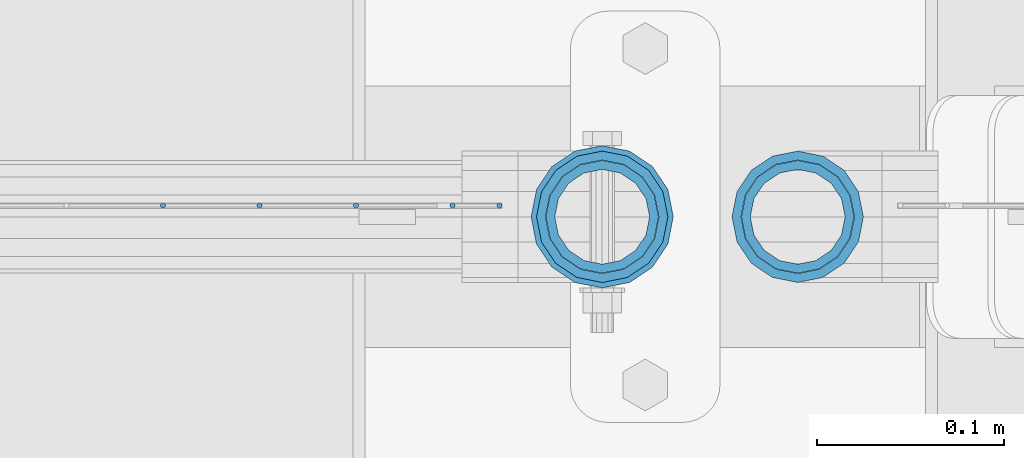
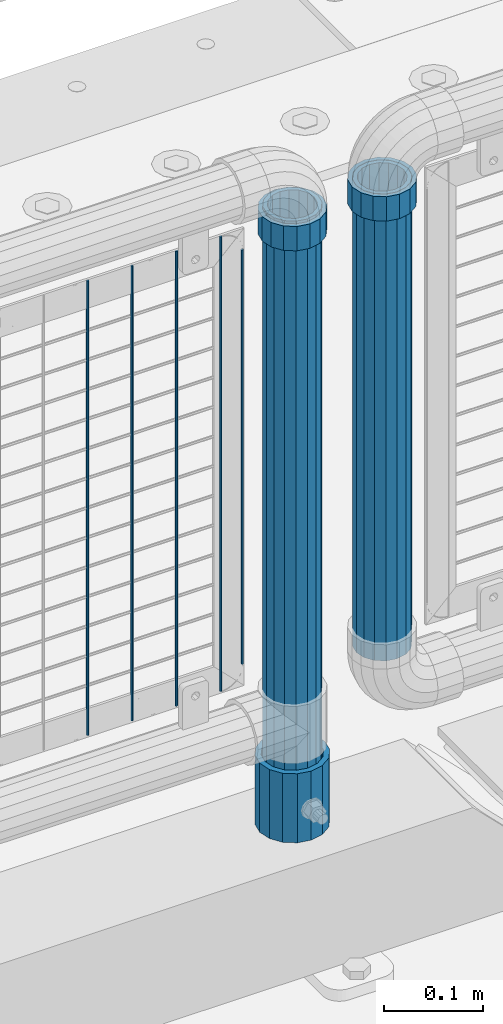
# One storey, part 95 of 240: 10 columns.
"""IFC2X3 building model written with IfcOpenShell, lengths in millimetres."""

import ifcopenshell
import ifcopenshell.guid

model = None  # the IFC model being written
_history = None  # IfcOwnerHistory: only IFC2X3 demands one
_inside = {}  # id of a spatial element -> (the spatial element, [elements in it])
_under = {}  # id of a project, library or spatial element -> (it, [spatial elements below it])
_declared = {}  # id of a project -> (the project, [libraries it declares])
_typed = {}  # id of a type object -> (the type object, [elements of that type])
_made_of = {}  # id of a material, layer set ... -> (it, [elements and type objects made of it])


def new_model(schema):
    """Start an empty IFC model of exactly this schema.

    Asked for "IFC4X3", IfcOpenShell would pick the latest addendum, in which some entities
    have other attributes; the version numbers below select the first issue.
    IFC2X3 requires an IfcOwnerHistory on every rooted entity: one is made here for all.
    """
    global model, _history
    if schema == "IFC4X3":
        model = ifcopenshell.file(schema_version=(4, 3, 0, 0))
    else:
        model = ifcopenshell.file(schema=schema)
    _inside.clear()
    _under.clear()
    _declared.clear()
    _typed.clear()
    _made_of.clear()
    _history = None
    if model.schema == "IFC2X3":
        org = make("IfcOrganization", Name="unknown")
        user = make(
            "IfcPersonAndOrganization",
            ThePerson=make("IfcPerson", FamilyName="unknown"),
            TheOrganization=org,
        )
        app = make(
            "IfcApplication",
            ApplicationDeveloper=org,
            Version="unknown",
            ApplicationFullName="unknown",
            ApplicationIdentifier="unknown",
        )
        _history = make(
            "IfcOwnerHistory",
            OwningUser=user,
            OwningApplication=app,
            ChangeAction="ADDED",
            CreationDate=0,
        )
    return model


def make(cls, **values):
    """One entity of the class cls with the attributes given. An attribute that is None is left unset."""
    return model.create_entity(
        cls, **{name: value for name, value in values.items() if value is not None}
    )


def rooted(cls, **values):
    """An entity with a GlobalId (a new one), such as an element, a storey or a relation."""
    return make(cls, GlobalId=ifcopenshell.guid.new(), OwnerHistory=_history, **values)


def si_unit(unit_type, name, prefix=None):
    """IfcSIUnit, for example si_unit("LENGTHUNIT", "METRE", prefix="MILLI")."""
    return make("IfcSIUnit", UnitType=unit_type, Prefix=prefix, Name=name)


def assignment(units):
    """IfcUnitAssignment: the units of a project."""
    return None if units is None else make("IfcUnitAssignment", Units=units)


def point(xyz):
    """IfcCartesianPoint."""
    return None if xyz is None else make("IfcCartesianPoint", Coordinates=xyz)


def direction(xyz):
    """IfcDirection."""
    return None if xyz is None else make("IfcDirection", DirectionRatios=xyz)


def frame(location, z_axis=None, x_axis=None):
    """IfcAxis2Placement3D, a coordinate frame: its origin and axes. An axis left out is left unset."""
    return make(
        "IfcAxis2Placement3D",
        Location=point(location),
        Axis=direction(z_axis),
        RefDirection=direction(x_axis),
    )


def origin_with_axes():
    """The frame at (0, 0, 0) with the z axis (0, 0, 1) and the x axis (1, 0, 0) written out."""
    return frame((0.0, 0.0, 0.0), z_axis=(0.0, 0.0, 1.0), x_axis=(1.0, 0.0, 0.0))


def place(relative_to, where):
    """IfcLocalPlacement: puts the frame where relative to a parent placement (None: the world)."""
    return make(
        "IfcLocalPlacement", PlacementRelTo=relative_to, RelativePlacement=where
    )


def context(
    kind, dimensions, precision=None, world=None, true_north=None, identifier=None
):
    """IfcGeometricRepresentationContext, for example the 3D "Model" context."""
    return make(
        "IfcGeometricRepresentationContext",
        ContextIdentifier=identifier,
        ContextType=kind,
        CoordinateSpaceDimension=dimensions,
        Precision=precision,
        WorldCoordinateSystem=world,
        TrueNorth=true_north,
    )


def subcontext(parent, identifier, kind, view, scale=None):
    """IfcGeometricRepresentationSubContext, for example "Body" below "Model"."""
    return make(
        "IfcGeometricRepresentationSubContext",
        ContextIdentifier=identifier,
        ContextType=kind,
        ParentContext=parent,
        TargetScale=scale,
        TargetView=view,
    )


def project(units=None, contexts=None):
    """IfcProject with its units and contexts."""
    return rooted(
        "IfcProject",
        Name="project",
        RepresentationContexts=contexts,
        UnitsInContext=assignment(units),
    )


def spatial(cls, under=None, at=None, **own):
    """A site, building, storey or space (cls), placed at a placement, below another one or the project."""
    s = rooted(cls, ObjectPlacement=at, **own)
    if under is not None:
        _under.setdefault(under.id(), (under, []))[1].append(s)
    return s


def faces_of(points, faces, orient=None, outer=None):
    """IfcFace entities. A face is a list of loops; a loop is a list of indices into points, from 0.

    orient and outer hold one flag for each loop. By default every Orientation is true, the
    first loop of a face is its IfcFaceOuterBound and the others are IfcFaceBound.
    """
    made = []
    for i, loops in enumerate(faces):
        bounds = []
        for j, loop in enumerate(loops):
            is_outer = j == 0 if outer is None else outer[i][j]
            bounds.append(
                make(
                    "IfcFaceOuterBound" if is_outer else "IfcFaceBound",
                    Bound=make("IfcPolyLoop", Polygon=[points[k] for k in loop]),
                    Orientation=True if orient is None else orient[i][j],
                )
            )
        made.append(make("IfcFace", Bounds=bounds))
    return made


def faceted_brep(points, faces, orient=None, outer=None, voids=None):
    """IfcFacetedBrep: a solid bounded by flat faces; with voids (closed shells), ...WithVoids."""
    shared = [point(p) for p in points]
    hull = make("IfcClosedShell", CfsFaces=faces_of(shared, faces, orient, outer))
    if voids is None:
        return make("IfcFacetedBrep", Outer=hull)
    return make(
        "IfcFacetedBrepWithVoids",
        Outer=hull,
        Voids=[
            make(cls, CfsFaces=faces_of(shared, fs, o, b)) for cls, fs, o, b in voids
        ],
    )


def shape(context_of_items, identifier, shape_type, items):
    """IfcShapeRepresentation: the items that make up one representation, for example the "Body"."""
    return make(
        "IfcShapeRepresentation",
        ContextOfItems=context_of_items,
        RepresentationIdentifier=identifier,
        RepresentationType=shape_type,
        Items=items,
    )


def material(Name=None, Category=None):
    """IfcMaterial."""
    return make("IfcMaterial", Name=Name, Category=Category)


def made_of(thing, what):
    """Note that an element or type object is made of a material, layer set ...; save() writes the relation."""
    if what is not None:
        _made_of.setdefault(what.id(), (what, []))[1].append(thing)
    return thing


def type_object(cls, material=None, **own):
    """A type object (cls), such as IfcWallType, which elements share."""
    return made_of(rooted(cls, **own), material)


def element(
    cls,
    number,
    at=None,
    inside=None,
    cuts=None,
    type_object=None,
    material=None,
    context=None,
    identifier="Body",
    shape_type=None,
    held_by="IfcProductDefinitionShape",
    body=None,
    shapes=None,
    **own,
):
    """One element of the class cls, such as IfcWall. Its Tag is "e" and its number.

    at: its placement. inside: the storey or other place that contains it. cuts: it is an
    opening in that element (IfcRelVoidsElement). A single representation is given by context,
    identifier, shape_type and body (its items); several are given by shapes. held_by: the class
    of the entity that holds the representations. save() writes the other relations.
    """
    e = rooted(cls, Tag="e%d" % number, ObjectPlacement=at, **own)
    if body is not None:
        shapes = [shape(context, identifier, shape_type, body)]
    if shapes is not None:
        e.Representation = make(held_by, Representations=shapes)
    if inside is not None:
        _inside.setdefault(inside.id(), (inside, []))[1].append(e)
    if cuts is not None:
        rooted(
            "IfcRelVoidsElement", RelatingBuildingElement=cuts, RelatedOpeningElement=e
        )
    if type_object is not None:
        _typed.setdefault(type_object.id(), (type_object, []))[1].append(e)
    return made_of(e, material)


def aggregate(whole, parts):
    """IfcRelAggregates: a whole, such as a stair, and the parts it consists of."""
    return rooted("IfcRelAggregates", RelatingObject=whole, RelatedObjects=parts)


def save(model, path):
    """Write the relations noted so far, then the file.

    IfcRelAggregates (storeys below a building ...), IfcRelContainedInSpatialStructure (elements
    in a storey), IfcRelDefinesByType, IfcRelAssociatesMaterial and IfcRelDeclares: one each for
    every whole, place, type object, material and project.
    """
    for whole, parts in _under.values():
        aggregate(whole, parts)
    for where, things in _inside.values():
        rooted(
            "IfcRelContainedInSpatialStructure",
            RelatedElements=things,
            RelatingStructure=where,
        )
    for kind, things in _typed.values():
        rooted("IfcRelDefinesByType", RelatedObjects=things, RelatingType=kind)
    for what, things in _made_of.values():
        rooted("IfcRelAssociatesMaterial", RelatedObjects=things, RelatingMaterial=what)
    for by, libraries in _declared.values():
        rooted("IfcRelDeclares", RelatingContext=by, RelatedDefinitions=libraries)
    model.write(path)


model = new_model("IFC2X3")

# Units and contexts
model_context = context("Model", 3, precision=1e-05, world=origin_with_axes())
body_context = subcontext(model_context, "Body", "Model", "MODEL_VIEW")
ifc_project = project(units=[si_unit("LENGTHUNIT", "METRE", prefix="MILLI"), si_unit("AREAUNIT", "SQUARE_METRE"), si_unit("VOLUMEUNIT", "CUBIC_METRE"), si_unit("MASSUNIT", "GRAM", prefix="KILO"), si_unit("TIMEUNIT", "SECOND"), si_unit("PLANEANGLEUNIT", "RADIAN"), si_unit("SOLIDANGLEUNIT", "STERADIAN"), si_unit("THERMODYNAMICTEMPERATUREUNIT", "DEGREE_CELSIUS"), si_unit("LUMINOUSINTENSITYUNIT", "LUMEN")], contexts=[model_context])

# Site, building, storey
site_placement = place(None, origin_with_axes())
site = spatial("IfcSite", under=ifc_project, at=site_placement, CompositionType="ELEMENT")
building_placement = place(site_placement, origin_with_axes())
building = spatial("IfcBuilding", under=site, at=building_placement, Name="Standard", CompositionType="ELEMENT")
storey_placement = place(building_placement, origin_with_axes())
storey = spatial("IfcBuildingStorey", under=building, at=storey_placement, Name="Undefined", CompositionType="ELEMENT", Elevation=0.0)

# Columns
ifc_material_1 = material(Name="Misc_Undefined")
column_type_1 = type_object("IfcColumnType", PredefinedType="NOTDEFINED")
column_1_placement = place(storey_placement, frame((54677.0, 34664.5, 894.85), z_axis=(1.0, 0.0, 0.0), x_axis=(0.0, 0.0, 1.0)))
element("IfcColumn", 1, at=column_1_placement, inside=storey, type_object=column_type_1, material=ifc_material_1, context=body_context, shape_type="Brep", body=[
    faceted_brep([(0.0, -30.3499999999985, 0.0), (0.0, -28.0397438117143, 11.6144421722784), (30.0, -28.0397438117143, 11.6144421722805), (30.0, -30.3499999999985, 0.0), (0.0, -21.4606908090136, 21.4606908090136), (30.0, -21.4606908090136, 21.4606908090117), (0.0, -11.6144421722784, 28.0397438117143), (30.0, -11.6144421722784, 28.0397438117176), (0.0, 0.0, 30.3499999999985), (30.0, 0.0, 30.35), (0.0, 11.6144421722784, 28.0397438117143), (30.0, 11.6144421722784, 28.0397438117176), (0.0, 21.4606908090136, 21.4606908090136), (30.0, 21.4606908090136, 21.4606908090117), (0.0, 28.0397438117143, 11.6144421722784), (30.0, 28.0397438117143, 11.6144421722805), (0.0, 30.3499999999985, 0.0), (30.0, 30.3499999999985, 0.0), (0.0, 28.0397438117143, -11.6144421722784), (30.0, 28.0397438117143, -11.6144421722805), (0.0, 21.4606908090136, -21.4606908090136), (30.0, 21.4606908090136, -21.4606908090117), (0.0, 11.6144421722784, -28.0397438117143), (30.0, 11.6144421722784, -28.0397438117176), (0.0, 0.0, -30.3499999999985), (30.0, 0.0, -30.35), (0.0, -11.6144421722784, -28.0397438117143), (30.0, -11.6144421722784, -28.0397438117176), (0.0, -21.4606908090136, -21.4606908090136), (30.0, -21.4606908090136, -21.4606908090117), (0.0, -28.0397438117143, -11.6144421722784), (30.0, -28.0397438117143, -11.6144421722805), (0.0, -35.1500000000015, 0.0), (0.0, -32.4743655677739, -13.4513226476338), (30.0, -32.4743655677739, -13.4513226476329), (30.0, -35.1500000000015, 0.0), (0.0, -24.8548033587067, -24.8548033587067), (30.0, -24.8548033587067, -24.8548033587072), (0.0, -13.4513226476338, -32.4743655677739), (30.0, -13.4513226476338, -32.4743655677718), (0.0, 0.0, -35.1500000000015), (30.0, 0.0, -35.15), (0.0, 13.4513226476338, -32.4743655677739), (30.0, 13.4513226476338, -32.4743655677718), (0.0, 24.8548033587067, -24.8548033587067), (30.0, 24.8548033587067, -24.8548033587072), (0.0, 32.4743655677739, -13.4513226476338), (30.0, 32.4743655677739, -13.4513226476329), (0.0, 35.1500000000015, 0.0), (30.0, 35.1500000000015, 0.0), (0.0, 32.4743655677739, 13.4513226476338), (30.0, 32.4743655677739, 13.4513226476329), (0.0, 24.8548033587067, 24.8548033587067), (30.0, 24.8548033587067, 24.8548033587072), (0.0, 13.4513226476338, 32.4743655677739), (30.0, 13.4513226476338, 32.4743655677718), (0.0, 0.0, 35.1500000000015), (30.0, 0.0, 35.15), (0.0, -13.4513226476338, 32.4743655677739), (30.0, -13.4513226476338, 32.4743655677718), (0.0, -24.8548033587067, 24.8548033587067), (30.0, -24.8548033587067, 24.8548033587072), (0.0, -32.4743655677739, 13.4513226476338), (30.0, -32.4743655677739, 13.4513226476329)], [[[0, 1, 2, 3]], [[1, 4, 5, 2]], [[4, 6, 7, 5]], [[6, 8, 9, 7]], [[8, 10, 11, 9]], [[10, 12, 13, 11]], [[12, 14, 15, 13]], [[14, 16, 17, 15]], [[16, 18, 19, 17]], [[18, 20, 21, 19]], [[20, 22, 23, 21]], [[22, 24, 25, 23]], [[24, 26, 27, 25]], [[26, 28, 29, 27]], [[28, 30, 31, 29]], [[30, 0, 3, 31]], [[32, 33, 34, 35]], [[33, 36, 37, 34]], [[36, 38, 39, 37]], [[38, 40, 41, 39]], [[40, 42, 43, 41]], [[42, 44, 45, 43]], [[44, 46, 47, 45]], [[46, 48, 49, 47]], [[48, 50, 51, 49]], [[50, 52, 53, 51]], [[52, 54, 55, 53]], [[54, 56, 57, 55]], [[56, 58, 59, 57]], [[58, 60, 61, 59]], [[60, 62, 63, 61]], [[62, 32, 35, 63]], [[37, 39, 41, 43, 45, 47, 49, 51, 53, 55, 57, 59, 61, 63, 35, 34], [5, 7, 9, 11, 13, 15, 17, 19, 21, 23, 25, 27, 29, 31, 3, 2]], [[62, 60, 58, 56, 54, 52, 50, 48, 46, 44, 42, 40, 38, 36, 33, 32], [30, 28, 26, 24, 22, 20, 18, 16, 14, 12, 10, 8, 6, 4, 1, 0]]]),
])
column_2_placement = place(storey_placement, frame((54781.61, 34664.5, 894.849999999999), z_axis=(-1.0, 0.0, 0.0), x_axis=(0.0, 0.0, 1.0)))
element("IfcColumn", 2, at=column_2_placement, inside=storey, type_object=column_type_1, material=ifc_material_1, context=body_context, shape_type="Brep", body=[
    faceted_brep([(0.0, -30.3499999999985, 0.0), (0.0, -28.0397438117143, 11.6144421722784), (30.0, -28.0397438117143, 11.6144421722805), (30.0, -30.3499999999985, 0.0), (0.0, -21.4606908090136, 21.4606908090136), (30.0, -21.4606908090136, 21.4606908090117), (0.0, -11.6144421722784, 28.0397438117143), (30.0, -11.6144421722784, 28.0397438117176), (0.0, 0.0, 30.3499999999985), (30.0, 0.0, 30.35), (0.0, 11.6144421722784, 28.0397438117143), (30.0, 11.6144421722784, 28.0397438117176), (0.0, 21.4606908090136, 21.4606908090136), (30.0, 21.4606908090136, 21.4606908090117), (0.0, 28.0397438117143, 11.6144421722784), (30.0, 28.0397438117143, 11.6144421722805), (0.0, 30.3499999999985, 0.0), (30.0, 30.3499999999985, 0.0), (0.0, 28.0397438117143, -11.6144421722784), (30.0, 28.0397438117143, -11.6144421722805), (0.0, 21.4606908090136, -21.4606908090136), (30.0, 21.4606908090136, -21.4606908090117), (0.0, 11.6144421722784, -28.0397438117143), (30.0, 11.6144421722784, -28.0397438117176), (0.0, 0.0, -30.3499999999985), (30.0, 0.0, -30.35), (0.0, -11.6144421722784, -28.0397438117143), (30.0, -11.6144421722784, -28.0397438117176), (0.0, -21.4606908090136, -21.4606908090136), (30.0, -21.4606908090136, -21.4606908090117), (0.0, -28.0397438117143, -11.6144421722784), (30.0, -28.0397438117143, -11.6144421722805), (0.0, -35.1500000000015, 0.0), (0.0, -32.4743655677739, -13.4513226476338), (30.0, -32.4743655677739, -13.4513226476329), (30.0, -35.1500000000015, 0.0), (0.0, -24.8548033587067, -24.8548033587067), (30.0, -24.8548033587067, -24.8548033587072), (0.0, -13.4513226476338, -32.4743655677739), (30.0, -13.4513226476338, -32.4743655677718), (0.0, 0.0, -35.1500000000015), (30.0, 0.0, -35.15), (0.0, 13.4513226476338, -32.4743655677739), (30.0, 13.4513226476338, -32.4743655677718), (0.0, 24.8548033587067, -24.8548033587067), (30.0, 24.8548033587067, -24.8548033587072), (0.0, 32.4743655677739, -13.4513226476338), (30.0, 32.4743655677739, -13.4513226476329), (0.0, 35.1500000000015, 0.0), (30.0, 35.1500000000015, 0.0), (0.0, 32.4743655677739, 13.4513226476338), (30.0, 32.4743655677739, 13.4513226476329), (0.0, 24.8548033587067, 24.8548033587067), (30.0, 24.8548033587067, 24.8548033587072), (0.0, 13.4513226476338, 32.4743655677739), (30.0, 13.4513226476338, 32.4743655677718), (0.0, 0.0, 35.1500000000015), (30.0, 0.0, 35.15), (0.0, -13.4513226476338, 32.4743655677739), (30.0, -13.4513226476338, 32.4743655677718), (0.0, -24.8548033587067, 24.8548033587067), (30.0, -24.8548033587067, 24.8548033587072), (0.0, -32.4743655677739, 13.4513226476338), (30.0, -32.4743655677739, 13.4513226476329)], [[[0, 1, 2, 3]], [[1, 4, 5, 2]], [[4, 6, 7, 5]], [[6, 8, 9, 7]], [[8, 10, 11, 9]], [[10, 12, 13, 11]], [[12, 14, 15, 13]], [[14, 16, 17, 15]], [[16, 18, 19, 17]], [[18, 20, 21, 19]], [[20, 22, 23, 21]], [[22, 24, 25, 23]], [[24, 26, 27, 25]], [[26, 28, 29, 27]], [[28, 30, 31, 29]], [[30, 0, 3, 31]], [[32, 33, 34, 35]], [[33, 36, 37, 34]], [[36, 38, 39, 37]], [[38, 40, 41, 39]], [[40, 42, 43, 41]], [[42, 44, 45, 43]], [[44, 46, 47, 45]], [[46, 48, 49, 47]], [[48, 50, 51, 49]], [[50, 52, 53, 51]], [[52, 54, 55, 53]], [[54, 56, 57, 55]], [[56, 58, 59, 57]], [[58, 60, 61, 59]], [[60, 62, 63, 61]], [[62, 32, 35, 63]], [[37, 39, 41, 43, 45, 47, 49, 51, 53, 55, 57, 59, 61, 63, 35, 34], [5, 7, 9, 11, 13, 15, 17, 19, 21, 23, 25, 27, 29, 31, 3, 2]], [[62, 60, 58, 56, 54, 52, 50, 48, 46, 44, 42, 40, 38, 36, 33, 32], [30, 28, 26, 24, 22, 20, 18, 16, 14, 12, 10, 8, 6, 4, 1, 0]]]),
])
ifc_material_2 = material()
column_type_2 = type_object("IfcColumnType", PredefinedType="NOTDEFINED")
column_3_placement = place(storey_placement, frame((54677.0, 34664.5, 168.02), z_axis=(-1.0, 0.0, 0.0), x_axis=(0.0, 0.0, 1.0)))
element("IfcColumn", 3, at=column_3_placement, inside=storey, type_object=column_type_2, material=ifc_material_2, context=body_context, shape_type="Brep", body=[
    faceted_brep([(0.0, -25.3499999999985, 0.0), (0.0, -23.4203461491634, 9.70102501045767), (760.0, -23.4203461491634, 9.70102501045767), (760.0, -25.3499999999985, 0.0), (0.0, -17.9251569030821, 17.9251569030821), (760.0, -17.9251569030821, 17.9251569030821), (0.0, -9.70102501045767, 23.4203461491634), (760.0, -9.70102501045767, 23.4203461491634), (0.0, 0.0, 25.3499999999985), (760.0, 0.0, 25.3499999999985), (0.0, 9.70102501045767, 23.4203461491634), (760.0, 9.70102501045767, 23.4203461491634), (0.0, 17.9251569030821, 17.9251569030821), (760.0, 17.9251569030821, 17.9251569030821), (0.0, 23.4203461491634, 9.70102501045767), (760.0, 23.4203461491634, 9.70102501045767), (0.0, 25.3499999999985, 0.0), (760.0, 25.3499999999985, 0.0), (0.0, 23.4203461491634, -9.70102501045767), (760.0, 23.4203461491634, -9.70102501045767), (0.0, 17.9251569030821, -17.9251569030821), (760.0, 17.9251569030821, -17.9251569030821), (0.0, 9.70102501045767, -23.4203461491634), (760.0, 9.70102501045767, -23.4203461491634), (0.0, 0.0, -25.3499999999985), (760.0, 0.0, -25.3499999999985), (0.0, -9.70102501045767, -23.4203461491634), (760.0, -9.70102501045767, -23.4203461491634), (0.0, -17.9251569030821, -17.9251569030821), (760.0, -17.9251569030821, -17.9251569030821), (0.0, -23.4203461491634, -9.70102501045767), (760.0, -23.4203461491634, -9.70102501045767), (0.0, -30.1500000000015, 0.0), (0.0, -27.8549679052157, -11.5379054858058), (760.0, -27.8549679052157, -11.5379054858058), (760.0, -30.1500000000015, 0.0), (0.0, -21.3192694527752, -21.3192694527752), (760.0, -21.3192694527752, -21.3192694527752), (0.0, -11.5379054858058, -27.8549679052157), (760.0, -11.5379054858058, -27.8549679052157), (0.0, 0.0, -30.1500000000015), (760.0, 0.0, -30.1500000000015), (0.0, 11.5379054858058, -27.8549679052157), (760.0, 11.5379054858058, -27.8549679052157), (0.0, 21.3192694527752, -21.3192694527752), (760.0, 21.3192694527752, -21.3192694527752), (0.0, 27.8549679052157, -11.5379054858058), (760.0, 27.8549679052157, -11.5379054858058), (0.0, 30.1500000000015, 0.0), (760.0, 30.1500000000015, 0.0), (0.0, 27.8549679052157, 11.5379054858058), (760.0, 27.8549679052157, 11.5379054858058), (0.0, 21.3192694527752, 21.3192694527752), (760.0, 21.3192694527752, 21.3192694527752), (0.0, 11.5379054858058, 27.8549679052157), (760.0, 11.5379054858058, 27.8549679052157), (0.0, 0.0, 30.1500000000015), (760.0, 0.0, 30.1500000000015), (0.0, -11.5379054858058, 27.8549679052157), (760.0, -11.5379054858058, 27.8549679052157), (0.0, -21.3192694527752, 21.3192694527752), (760.0, -21.3192694527752, 21.3192694527752), (0.0, -27.8549679052157, 11.5379054858058), (760.0, -27.8549679052157, 11.5379054858058)], [[[0, 1, 2, 3]], [[1, 4, 5, 2]], [[4, 6, 7, 5]], [[6, 8, 9, 7]], [[8, 10, 11, 9]], [[10, 12, 13, 11]], [[12, 14, 15, 13]], [[14, 16, 17, 15]], [[16, 18, 19, 17]], [[18, 20, 21, 19]], [[20, 22, 23, 21]], [[22, 24, 25, 23]], [[24, 26, 27, 25]], [[26, 28, 29, 27]], [[28, 30, 31, 29]], [[30, 0, 3, 31]], [[32, 33, 34, 35]], [[33, 36, 37, 34]], [[36, 38, 39, 37]], [[38, 40, 41, 39]], [[40, 42, 43, 41]], [[42, 44, 45, 43]], [[44, 46, 47, 45]], [[46, 48, 49, 47]], [[48, 50, 51, 49]], [[50, 52, 53, 51]], [[52, 54, 55, 53]], [[54, 56, 57, 55]], [[56, 58, 59, 57]], [[58, 60, 61, 59]], [[60, 62, 63, 61]], [[62, 32, 35, 63]], [[37, 39, 41, 43, 45, 47, 49, 51, 53, 55, 57, 59, 61, 63, 35, 34], [5, 7, 9, 11, 13, 15, 17, 19, 21, 23, 25, 27, 29, 31, 3, 2]], [[62, 60, 58, 56, 54, 52, 50, 48, 46, 44, 42, 40, 38, 36, 33, 32], [30, 28, 26, 24, 22, 20, 18, 16, 14, 12, 10, 8, 6, 4, 1, 0]]]),
])
column_4_placement = place(storey_placement, frame((54781.61, 34664.5, 349.86), z_axis=(-1.0, 0.0, 0.0), x_axis=(0.0, 0.0, 1.0)))
element("IfcColumn", 4, at=column_4_placement, inside=storey, type_object=column_type_2, material=ifc_material_2, context=body_context, shape_type="Brep", body=[
    faceted_brep([(0.0, -25.3499999999985, 0.0), (0.0, -23.4203461491634, 9.70102501045767), (574.992910334213, -23.4203461491634, 9.70102501045767), (574.990000024649, -25.3499999999985, 0.0), (0.0, -17.9251569030821, 17.9251569030821), (574.995377579387, -17.9251569030821, 17.9251569030821), (0.0, -9.70102501045767, 23.4203461491634), (574.997026144459, -9.70102501045767, 23.4203461491634), (0.0, 0.0, 25.3499999999985), (574.997605050341, 0.0, 25.3499999999985), (0.0, 9.70102501045767, 23.4203461491634), (574.997026163861, 9.70102501045767, 23.4203461491634), (0.0, 17.9251569030821, 17.9251569030821), (574.995377615237, 17.9251569030821, 17.9251569030821), (0.0, 23.4203461491634, 9.70102501045767), (574.992910381054, 23.4203461491634, 9.70102501045767), (0.0, 25.3499999999985, 0.0), (574.990000075349, 25.3499999999985, 0.0), (0.0, 23.4203461491634, -9.70102501045767), (574.987089765785, 23.4203461491634, -9.70102501045767), (0.0, 17.9251569030821, -17.9251569030821), (574.984622520612, 17.9251569030821, -17.9251569030821), (0.0, 9.70102501045767, -23.4203461491634), (574.982973955539, 9.70102501045767, -23.4203461491634), (0.0, 0.0, -25.3499999999985), (574.982395049657, 0.0, -25.3499999999985), (0.0, -9.70102501045767, -23.4203461491634), (574.982973936137, -9.70102501045767, -23.4203461491634), (0.0, -17.9251569030821, -17.9251569030821), (574.984622484761, -17.9251569030821, -17.9251569030821), (0.0, -23.4203461491634, -9.70102501045767), (574.987089718945, -23.4203461491634, -9.70102501045767), (0.0, -30.1500000000015, 0.0), (0.0, -27.8549679052157, -11.5379054858058), (574.986538650343, -27.8549679052157, -11.5379054858058), (574.990000019849, -30.1500000000015, 0.0), (0.0, -21.3192694527752, -21.3192694527752), (574.983604247556, -21.3192694527752, -21.3192694527752), (0.0, -11.5379054858058, -27.8549679052157), (574.981643547714, -11.5379054858058, -27.8549679052157), (0.0, 0.0, -30.1500000000015), (574.980955049592, 0.0, -30.1500000000015), (0.0, 11.5379054858058, -27.8549679052157), (574.98164357079, 11.5379054858058, -27.8549679052157), (0.0, 21.3192694527752, -21.3192694527752), (574.983604290195, 21.3192694527752, -21.3192694527752), (0.0, 27.8549679052157, -11.5379054858058), (574.986538706053, 27.8549679052157, -11.5379054858058), (0.0, 30.1500000000015, 0.0), (574.990000080149, 30.1500000000015, 0.0), (0.0, 27.8549679052157, 11.5379054858058), (574.993461449656, 27.8549679052157, 11.5379054858058), (0.0, 21.3192694527752, 21.3192694527752), (574.996395852442, 21.3192694527752, 21.3192694527752), (0.0, 11.5379054858058, 27.8549679052157), (574.998356552285, 11.5379054858058, 27.8549679052157), (0.0, 0.0, 30.1500000000015), (574.999045050406, 0.0, 30.1500000000015), (0.0, -11.5379054858058, 27.8549679052157), (574.998356529209, -11.5379054858058, 27.8549679052157), (0.0, -21.3192694527752, 21.3192694527752), (574.996395809804, -21.3192694527752, 21.3192694527752), (0.0, -27.8549679052157, 11.5379054858058), (574.993461393946, -27.8549679052157, 11.5379054858058)], [[[0, 1, 2, 3]], [[1, 4, 5, 2]], [[4, 6, 7, 5]], [[6, 8, 9, 7]], [[8, 10, 11, 9]], [[10, 12, 13, 11]], [[12, 14, 15, 13]], [[14, 16, 17, 15]], [[16, 18, 19, 17]], [[18, 20, 21, 19]], [[20, 22, 23, 21]], [[22, 24, 25, 23]], [[24, 26, 27, 25]], [[26, 28, 29, 27]], [[28, 30, 31, 29]], [[30, 0, 3, 31]], [[32, 33, 34, 35]], [[33, 36, 37, 34]], [[36, 38, 39, 37]], [[38, 40, 41, 39]], [[40, 42, 43, 41]], [[42, 44, 45, 43]], [[44, 46, 47, 45]], [[46, 48, 49, 47]], [[48, 50, 51, 49]], [[50, 52, 53, 51]], [[52, 54, 55, 53]], [[54, 56, 57, 55]], [[56, 58, 59, 57]], [[58, 60, 61, 59]], [[60, 62, 63, 61]], [[62, 32, 35, 63]], [[37, 39, 41, 43, 45, 47, 49, 51, 53, 55, 57, 59, 61, 63, 35, 34], [5, 7, 9, 11, 13, 15, 17, 19, 21, 23, 25, 27, 29, 31, 3, 2]], [[62, 60, 58, 56, 54, 52, 50, 48, 46, 44, 42, 40, 38, 36, 33, 32], [30, 28, 26, 24, 22, 20, 18, 16, 14, 12, 10, 8, 6, 4, 1, 0]]]),
])
column_type_3 = type_object("IfcColumnType", Name="D3", PredefinedType="NOTDEFINED")
for number, where, z_axis, x_axis in (
    (5, (54545.34, 34670.5, 353.020000000001), (-1.0, 0.0, 0.0), (0.0, 0.0, 1.0)),
    (6, (54493.685, 34670.5, 353.020000000001), (-1.0, 0.0, 0.0), (0.0, 0.0, 1.0)),
    (7, (54442.03, 34670.5, 353.020000000001), (-1.0, 0.0, 0.0), (0.0, 0.0, 1.0)),
    (8, (54596.995, 34670.5, 353.020000000001), (-1.0, 0.0, 0.0), (0.0, 0.0, 1.0)),
):
    element("IfcColumn", number, at=place(storey_placement, frame(where, z_axis=z_axis, x_axis=x_axis)), inside=storey, type_object=column_type_3, material=ifc_material_1, ObjectType="D3", context=body_context, shape_type="Brep", body=[
        faceted_brep([(-7.27595761418343e-12, -1.49999999999272, 0.0), (-7.27595761418343e-12, -0.749999999992724, -1.29903810567669), (560.0, -0.75, -1.29903810567339), (560.0, -1.5, 0.0), (0.0, 0.750000000007276, -1.29903810567669), (560.0, 0.75, -1.29903810567339), (0.0, 1.50000000000728, 0.0), (560.0, 1.5, 0.0), (0.0, 0.750000000007276, 1.29903810567669), (560.0, 0.75, 1.29903810567339), (-7.27595761418343e-12, -0.749999999992724, 1.29903810567669), (560.0, -0.75, 1.29903810567339)], [[[0, 1, 2, 3]], [[1, 4, 5, 2]], [[4, 6, 7, 5]], [[6, 8, 9, 7]], [[8, 10, 11, 9]], [[10, 0, 3, 11]], [[5, 7, 9, 11, 3, 2]], [[10, 8, 6, 4, 1, 0]]]),
    ])
column_5_placement = place(storey_placement, frame((54622.0, 34670.5, 378.020000000001), z_axis=(-1.0, 0.0, 0.0), x_axis=(0.0, 0.0, 1.0)))
element("IfcColumn", 9, at=column_5_placement, inside=storey, type_object=column_type_3, material=ifc_material_1, ObjectType="D3", context=body_context, shape_type="Brep", body=[
    faceted_brep([(-7.27595761418343e-12, -1.49999999999272, 0.0), (-7.27595761418343e-12, -0.749999999992724, -1.29903810567669), (510.0, -0.75, -1.29903810567339), (510.0, -1.5, 0.0), (0.0, 0.750000000007276, -1.29903810567669), (510.0, 0.75, -1.29903810567339), (0.0, 1.50000000000728, 0.0), (510.0, 1.5, 0.0), (0.0, 0.750000000007276, 1.29903810567669), (510.0, 0.75, 1.29903810567339), (-7.27595761418343e-12, -0.749999999992724, 1.29903810567669), (510.0, -0.75, 1.29903810567339)], [[[0, 1, 2, 3]], [[1, 4, 5, 2]], [[4, 6, 7, 5]], [[6, 8, 9, 7]], [[8, 10, 11, 9]], [[10, 0, 3, 11]], [[5, 7, 9, 11, 3, 2]], [[10, 8, 6, 4, 1, 0]]]),
])
column_type_4 = type_object("IfcColumnType", PredefinedType="NOTDEFINED")
column_6_placement = place(storey_placement, frame((54677.0, 34664.5, 168.02), z_axis=(0.0, 1.0, 0.0), x_axis=(0.0, 0.0, 1.0)))
element("IfcColumn", 10, at=column_6_placement, inside=storey, type_object=column_type_4, material=ifc_material_2, context=body_context, shape_type="Brep", body=[
    faceted_brep([(0.0, -31.75, 0.0), (0.0, -29.3331751572332, 12.1501989775934), (85.0, -29.3331751572332, 12.1501989775934), (85.0, -31.75, 0.0), (0.0, -22.4506403026753, 22.4506403026753), (85.0, -22.4506403026753, 22.4506403026753), (0.0, -12.1501989775934, 29.3331751572332), (85.0, -12.1501989775934, 29.3331751572332), (0.0, 0.0, 31.75), (85.0, 0.0, 31.75), (0.0, 12.1501989775934, 29.3331751572332), (85.0, 12.1501989775934, 29.3331751572332), (0.0, 22.4506403026753, 22.4506403026753), (85.0, 22.4506403026753, 22.4506403026753), (0.0, 29.3331751572332, 12.1501989775934), (85.0, 29.3331751572332, 12.1501989775934), (0.0, 31.75, 0.0), (85.0, 31.75, 0.0), (0.0, 29.3331751572332, -12.1501989775934), (85.0, 29.3331751572332, -12.1501989775934), (0.0, 22.4506403026753, -22.4506403026753), (85.0, 22.4506403026753, -22.4506403026753), (0.0, 12.1501989775934, -29.3331751572332), (85.0, 12.1501989775934, -29.3331751572332), (0.0, 0.0, -31.75), (85.0, 0.0, -31.75), (0.0, -12.1501989775934, -29.3331751572332), (85.0, -12.1501989775934, -29.3331751572332), (0.0, -22.4506403026753, -22.4506403026753), (85.0, -22.4506403026753, -22.4506403026753), (0.0, -29.3331751572332, -12.1501989775934), (85.0, -29.3331751572332, -12.1501989775934), (0.0, -38.0500000000029, 0.0), (0.0, -35.1536162120537, -14.5611046014892), (85.0, -35.1536162120537, -14.5611046014892), (85.0, -38.0500000000029, 0.0), (0.0, -26.9054130241493, -26.9054130241493), (85.0, -26.9054130241493, -26.9054130241493), (0.0, -14.5611046014892, -35.1536162120537), (85.0, -14.5611046014892, -35.1536162120537), (0.0, 0.0, -38.0500000000029), (85.0, 0.0, -38.0500000000029), (0.0, 14.5611046014892, -35.1536162120537), (85.0, 14.5611046014892, -35.1536162120537), (0.0, 26.9054130241493, -26.9054130241493), (85.0, 26.9054130241493, -26.9054130241493), (0.0, 35.1536162120537, -14.5611046014892), (85.0, 35.1536162120537, -14.5611046014892), (0.0, 38.0500000000029, 0.0), (85.0, 38.0500000000029, 0.0), (0.0, 35.1536162120537, 14.5611046014892), (85.0, 35.1536162120537, 14.5611046014892), (0.0, 26.9054130241493, 26.9054130241493), (85.0, 26.9054130241493, 26.9054130241493), (0.0, 14.5611046014892, 35.1536162120537), (85.0, 14.5611046014892, 35.1536162120537), (0.0, 0.0, 38.0500000000029), (85.0, 0.0, 38.0500000000029), (0.0, -14.5611046014892, 35.1536162120537), (85.0, -14.5611046014892, 35.1536162120537), (0.0, -26.9054130241493, 26.9054130241493), (85.0, -26.9054130241493, 26.9054130241493), (0.0, -35.1536162120537, 14.5611046014892), (85.0, -35.1536162120537, 14.5611046014892)], [[[0, 1, 2, 3]], [[1, 4, 5, 2]], [[4, 6, 7, 5]], [[6, 8, 9, 7]], [[8, 10, 11, 9]], [[10, 12, 13, 11]], [[12, 14, 15, 13]], [[14, 16, 17, 15]], [[16, 18, 19, 17]], [[18, 20, 21, 19]], [[20, 22, 23, 21]], [[22, 24, 25, 23]], [[24, 26, 27, 25]], [[26, 28, 29, 27]], [[28, 30, 31, 29]], [[30, 0, 3, 31]], [[32, 33, 34, 35]], [[33, 36, 37, 34]], [[36, 38, 39, 37]], [[38, 40, 41, 39]], [[40, 42, 43, 41]], [[42, 44, 45, 43]], [[44, 46, 47, 45]], [[46, 48, 49, 47]], [[48, 50, 51, 49]], [[50, 52, 53, 51]], [[52, 54, 55, 53]], [[54, 56, 57, 55]], [[56, 58, 59, 57]], [[58, 60, 61, 59]], [[60, 62, 63, 61]], [[62, 32, 35, 63]], [[37, 39, 41, 43, 45, 47, 49, 51, 53, 55, 57, 59, 61, 63, 35, 34], [5, 7, 9, 11, 13, 15, 17, 19, 21, 23, 25, 27, 29, 31, 3, 2]], [[62, 60, 58, 56, 54, 52, 50, 48, 46, 44, 42, 40, 38, 36, 33, 32], [30, 28, 26, 24, 22, 20, 18, 16, 14, 12, 10, 8, 6, 4, 1, 0]]]),
])

save(model, "model.ifc")
